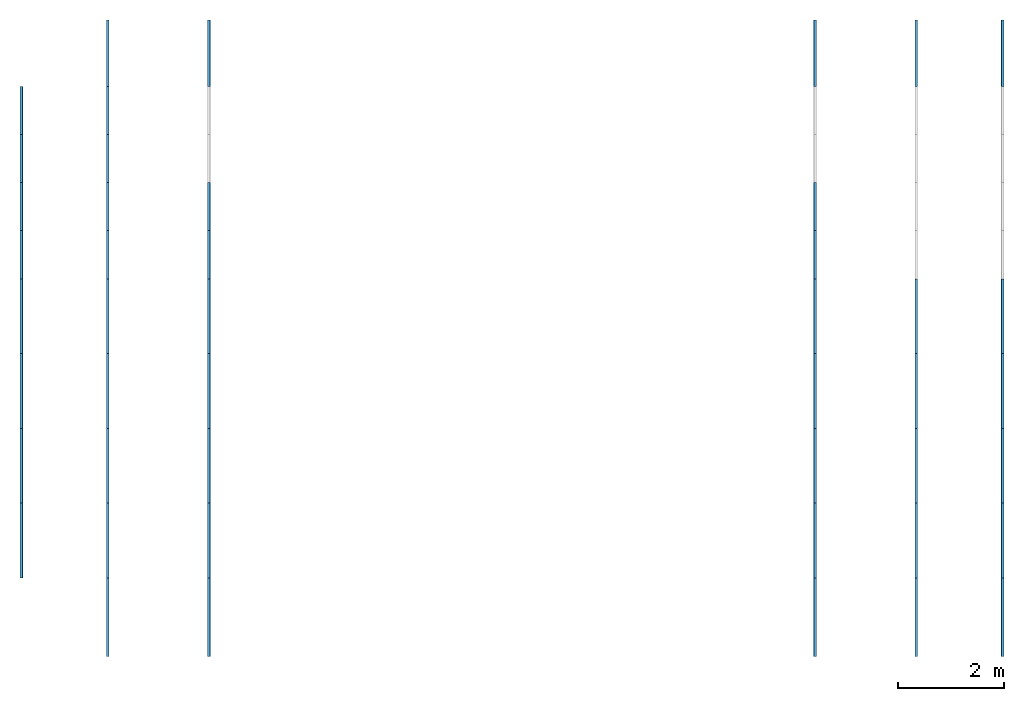
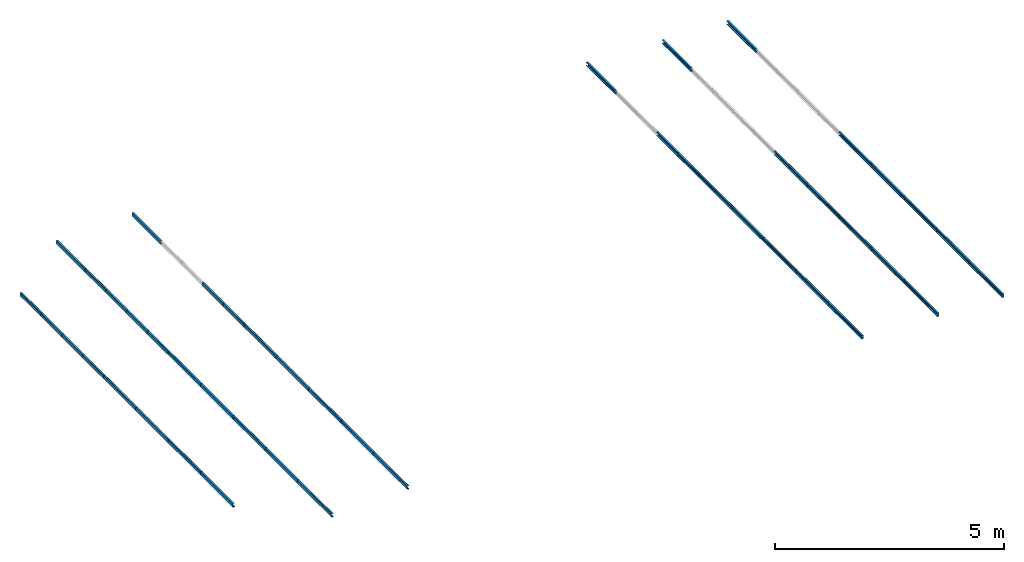
# One storey, part 1 of 2: 46 beams.
"""IFC4 building model written with IfcOpenShell, lengths in metres."""

from ifc_helpers import new_model, si_unit, derived_unit, frame, origin_with_axes, origin_2d_with_axis, place, context, project, spatial, c_section, extrude, material, material_profile, profile_set, profile_usage, element, save


model = new_model("IFC4")

# Units and contexts
model_context = context("Model", 3, world=origin_with_axes())
ifc_project = project(units=[si_unit("LENGTHUNIT", "METRE"), si_unit("AREAUNIT", "SQUARE_METRE"), si_unit("VOLUMEUNIT", "CUBIC_METRE"), derived_unit("SECTIONMODULUSUNIT", [(si_unit("LENGTHUNIT", "METRE"), 3)]), derived_unit("MOMENTOFINERTIAUNIT", [(si_unit("LENGTHUNIT", "METRE"), 4)]), si_unit("PLANEANGLEUNIT", "RADIAN"), si_unit("TIMEUNIT", "SECOND"), si_unit("THERMODYNAMICTEMPERATUREUNIT", "DEGREE_CELSIUS"), derived_unit("THERMALEXPANSIONCOEFFICIENTUNIT", [(si_unit("THERMODYNAMICTEMPERATUREUNIT", "DEGREE_CELSIUS"), -1)])], contexts=[model_context])

# Site, building, storey
site = spatial("IfcSite", under=ifc_project, CompositionType="ELEMENT")
building = spatial("IfcBuilding", under=site, Name="Building", CompositionType="ELEMENT")
storey = spatial("IfcBuildingStorey", under=building, Name="LEVEL 4", CompositionType="ELEMENT", Elevation=9.664)

# Beams
ifc_material = material(Name="SAE 1020")
ifc_material_profile_1 = material_profile(ifc_material, c_section(Depth=0.1, Width=0.05, WallThickness=0.003, Girth=0.017, InternalFilletRadius=0.003, at=origin_2d_with_axis()))
ifc_profile_set_1 = profile_set([ifc_material_profile_1])
ifc_profile_usage_1 = profile_usage(ifc_profile_set_1, cardinal=10)
beam_1_placement = place(None, frame((7.6291995, 8.75, 9.664), z_axis=(3.3783784e-07, 1.0, -3.0405405e-05), x_axis=(0.9992562, 8.3491316e-07, 0.038562213)))
element("IfcBeam", 1, at=beam_1_placement, inside=storey, material=ifc_profile_usage_1, Name="25", context=model_context, shape_type="SweptSolid", body=[
    extrude(c_section(Depth=0.1, Width=0.05, WallThickness=0.003, Girth=0.017, InternalFilletRadius=0.003, at=origin_2d_with_axis()), origin_with_axes(), (0.0, 0.0, 1.0), 1.48),
])
ifc_material_profile_2 = material_profile(ifc_material, c_section(Depth=0.1, Width=0.05, WallThickness=0.003, Girth=0.017, InternalFilletRadius=0.003, at=origin_2d_with_axis()))
ifc_profile_set_2 = profile_set([ifc_material_profile_2])
ifc_profile_usage_2 = profile_usage(ifc_profile_set_2, cardinal=10)
beam_2_placement = place(None, frame((7.6292, 19.5, 9.6639876), z_axis=(3.3783784e-07, 1.0, -3.0405405e-05), x_axis=(0.9992562, 8.3491316e-07, 0.038562213)))
element("IfcBeam", 2, at=beam_2_placement, inside=storey, material=ifc_profile_usage_2, Name="30", context=model_context, shape_type="SweptSolid", body=[
    extrude(c_section(Depth=0.1, Width=0.05, WallThickness=0.003, Girth=0.017, InternalFilletRadius=0.003, at=origin_2d_with_axis()), origin_with_axes(), (0.0, 0.0, 1.0), 1.25),
])
ifc_material_profile_3 = material_profile(ifc_material, c_section(Depth=0.1, Width=0.05, WallThickness=0.003, Girth=0.017, InternalFilletRadius=0.003, at=origin_2d_with_axis()))
ifc_profile_set_3 = profile_set([ifc_material_profile_3])
ifc_profile_usage_3 = profile_usage(ifc_profile_set_3, cardinal=10)
beam_3_placement = place(None, frame((9.5343995, 8.75, 9.7355), z_axis=(3.3783784e-07, 1.0, -3.0405405e-05), x_axis=(0.9992562, 8.3491316e-07, 0.038562213)))
element("IfcBeam", 3, at=beam_3_placement, inside=storey, material=ifc_profile_usage_3, Name="31", context=model_context, shape_type="SweptSolid", body=[
    extrude(c_section(Depth=0.1, Width=0.05, WallThickness=0.003, Girth=0.017, InternalFilletRadius=0.003, at=origin_2d_with_axis()), origin_with_axes(), (0.0, 0.0, 1.0), 1.48),
])
ifc_material_profile_4 = material_profile(ifc_material, c_section(Depth=0.1, Width=0.05, WallThickness=0.003, Girth=0.017, InternalFilletRadius=0.003, at=origin_2d_with_axis()))
ifc_profile_set_4 = profile_set([ifc_material_profile_4])
ifc_profile_usage_4 = profile_usage(ifc_profile_set_4, cardinal=10)
beam_4_placement = place(None, frame((9.5344, 19.5, 9.7354252), z_axis=(3.3783784e-07, 1.0, -3.0405405e-05), x_axis=(0.9992562, 8.3491316e-07, 0.038562213)))
element("IfcBeam", 4, at=beam_4_placement, inside=storey, material=ifc_profile_usage_4, Name="36", context=model_context, shape_type="SweptSolid", body=[
    extrude(c_section(Depth=0.1, Width=0.05, WallThickness=0.003, Girth=0.017, InternalFilletRadius=0.003, at=origin_2d_with_axis()), origin_with_axes(), (0.0, 0.0, 1.0), 1.25),
])
ifc_material_profile_5 = material_profile(ifc_material, c_section(Depth=0.1, Width=0.05, WallThickness=0.003, Girth=0.017, InternalFilletRadius=0.003, at=origin_2d_with_axis()))
ifc_profile_set_5 = profile_set([ifc_material_profile_5])
ifc_profile_usage_5 = profile_usage(ifc_profile_set_5, cardinal=10)
beam_5_placement = place(None, frame((24.5, 8.75, 9.6029), z_axis=(3.3783784e-07, 1.0, -3.0405405e-05), x_axis=(-0.9992562, 8.3491316e-07, 0.038562213)))
element("IfcBeam", 5, at=beam_5_placement, inside=storey, material=ifc_profile_usage_5, Name="150", context=model_context, shape_type="SweptSolid", body=[
    extrude(c_section(Depth=0.1, Width=0.05, WallThickness=0.003, Girth=0.017, InternalFilletRadius=0.003, at=origin_2d_with_axis()), origin_with_axes(), (0.0, 0.0, 1.0), 1.48),
])
ifc_material_profile_6 = material_profile(ifc_material, c_section(Depth=0.1, Width=0.05, WallThickness=0.003, Girth=0.017, InternalFilletRadius=0.003, at=origin_2d_with_axis()))
ifc_profile_set_6 = profile_set([ifc_material_profile_6])
ifc_profile_usage_6 = profile_usage(ifc_profile_set_6, cardinal=10)
beam_6_placement = place(None, frame((24.499999, 19.5, 9.602899), z_axis=(3.3783784e-07, 1.0, -3.0405405e-05), x_axis=(-0.9992562, 8.3491316e-07, 0.038562213)))
element("IfcBeam", 6, at=beam_6_placement, inside=storey, material=ifc_profile_usage_6, Name="155", context=model_context, shape_type="SweptSolid", body=[
    extrude(c_section(Depth=0.1, Width=0.05, WallThickness=0.003, Girth=0.017, InternalFilletRadius=0.003, at=origin_2d_with_axis()), origin_with_axes(), (0.0, 0.0, 1.0), 1.25),
])
ifc_material_profile_7 = material_profile(ifc_material, c_section(Depth=0.1, Width=0.05, WallThickness=0.003, Girth=0.017, InternalFilletRadius=0.003, at=origin_2d_with_axis()))
ifc_profile_set_7 = profile_set([ifc_material_profile_7])
ifc_profile_usage_7 = profile_usage(ifc_profile_set_7, cardinal=10)
beam_7_placement = place(None, frame((22.870801, 8.75, 9.664), z_axis=(3.3783784e-07, 1.0, -3.0405405e-05), x_axis=(-0.9992562, 8.3491316e-07, 0.038562213)))
element("IfcBeam", 7, at=beam_7_placement, inside=storey, material=ifc_profile_usage_7, Name="156", context=model_context, shape_type="SweptSolid", body=[
    extrude(c_section(Depth=0.1, Width=0.05, WallThickness=0.003, Girth=0.017, InternalFilletRadius=0.003, at=origin_2d_with_axis()), origin_with_axes(), (0.0, 0.0, 1.0), 1.48),
])
ifc_material_profile_8 = material_profile(ifc_material, c_section(Depth=0.1, Width=0.05, WallThickness=0.003, Girth=0.017, InternalFilletRadius=0.003, at=origin_2d_with_axis()))
ifc_profile_set_8 = profile_set([ifc_material_profile_8])
ifc_profile_usage_8 = profile_usage(ifc_profile_set_8, cardinal=10)
beam_8_placement = place(None, frame((22.8708, 19.5, 9.6639876), z_axis=(3.3783784e-07, 1.0, -3.0405405e-05), x_axis=(-0.9992562, 8.3491316e-07, 0.038562213)))
element("IfcBeam", 8, at=beam_8_placement, inside=storey, material=ifc_profile_usage_8, Name="161", context=model_context, shape_type="SweptSolid", body=[
    extrude(c_section(Depth=0.1, Width=0.05, WallThickness=0.003, Girth=0.017, InternalFilletRadius=0.003, at=origin_2d_with_axis()), origin_with_axes(), (0.0, 0.0, 1.0), 1.25),
])
ifc_material_profile_9 = material_profile(ifc_material, c_section(Depth=0.1, Width=0.05, WallThickness=0.003, Girth=0.017, InternalFilletRadius=0.003, at=origin_2d_with_axis()))
ifc_profile_set_9 = profile_set([ifc_material_profile_9])
ifc_profile_usage_9 = profile_usage(ifc_profile_set_9, cardinal=10)
beam_9_placement = place(None, frame((20.965601, 8.75, 9.7355), z_axis=(3.3783784e-07, 1.0, -3.0405405e-05), x_axis=(-0.9992562, 8.3491316e-07, 0.038562213)))
element("IfcBeam", 9, at=beam_9_placement, inside=storey, material=ifc_profile_usage_9, Name="162", context=model_context, shape_type="SweptSolid", body=[
    extrude(c_section(Depth=0.1, Width=0.05, WallThickness=0.003, Girth=0.017, InternalFilletRadius=0.003, at=origin_2d_with_axis()), origin_with_axes(), (0.0, 0.0, 1.0), 1.48),
])
ifc_material_profile_10 = material_profile(ifc_material, c_section(Depth=0.1, Width=0.05, WallThickness=0.003, Girth=0.017, InternalFilletRadius=0.003, at=origin_2d_with_axis()))
ifc_profile_set_10 = profile_set([ifc_material_profile_10])
ifc_profile_usage_10 = profile_usage(ifc_profile_set_10, cardinal=10)
beam_10_placement = place(None, frame((20.9656, 19.5, 9.7354252), z_axis=(3.3783784e-07, 1.0, -3.0405405e-05), x_axis=(-0.9992562, 8.3491316e-07, 0.038562213)))
element("IfcBeam", 10, at=beam_10_placement, inside=storey, material=ifc_profile_usage_10, Name="167", context=model_context, shape_type="SweptSolid", body=[
    extrude(c_section(Depth=0.1, Width=0.05, WallThickness=0.003, Girth=0.017, InternalFilletRadius=0.003, at=origin_2d_with_axis()), origin_with_axes(), (0.0, 0.0, 1.0), 1.25),
])
ifc_material_profile_11 = material_profile(ifc_material, c_section(Depth=0.1, Width=0.05, WallThickness=0.003, Girth=0.017, InternalFilletRadius=0.003, at=origin_2d_with_axis()))
ifc_profile_set_11 = profile_set([ifc_material_profile_11])
ifc_profile_usage_11 = profile_usage(ifc_profile_set_11, cardinal=10)
beam_11_placement = place(None, frame((6.0000007, 10.23, 9.602899), z_axis=(3.3783784e-07, 1.0, -3.0405405e-05), x_axis=(0.9992562, 8.3491316e-07, 0.038562213)))
element("IfcBeam", 11, at=beam_11_placement, inside=storey, material=ifc_profile_usage_11, Name="405", context=model_context, shape_type="SweptSolid", body=[
    extrude(c_section(Depth=0.1, Width=0.05, WallThickness=0.003, Girth=0.017, InternalFilletRadius=0.003, at=origin_2d_with_axis()), origin_with_axes(), (0.0, 0.0, 1.0), 1.41),
])
ifc_material_profile_12 = material_profile(ifc_material, c_section(Depth=0.1, Width=0.05, WallThickness=0.003, Girth=0.017, InternalFilletRadius=0.003, at=origin_2d_with_axis()))
ifc_profile_set_12 = profile_set([ifc_material_profile_12])
ifc_profile_usage_12 = profile_usage(ifc_profile_set_12, cardinal=10)
beam_12_placement = place(None, frame((6.0000007, 11.64, 9.602899), z_axis=(3.3783784e-07, 1.0, -3.0405405e-05), x_axis=(0.9992562, 8.3491316e-07, 0.038562213)))
element("IfcBeam", 12, at=beam_12_placement, inside=storey, material=ifc_profile_usage_12, Name="406", context=model_context, shape_type="SweptSolid", body=[
    extrude(c_section(Depth=0.1, Width=0.05, WallThickness=0.003, Girth=0.017, InternalFilletRadius=0.003, at=origin_2d_with_axis()), origin_with_axes(), (0.0, 0.0, 1.0), 1.41),
])
ifc_material_profile_13 = material_profile(ifc_material, c_section(Depth=0.1, Width=0.05, WallThickness=0.003, Girth=0.017, InternalFilletRadius=0.003, at=origin_2d_with_axis()))
ifc_profile_set_13 = profile_set([ifc_material_profile_13])
ifc_profile_usage_13 = profile_usage(ifc_profile_set_13, cardinal=10)
beam_13_placement = place(None, frame((6.0000007, 13.05, 9.602899), z_axis=(3.3783784e-07, 1.0, -3.0405405e-05), x_axis=(0.9992562, 8.3491316e-07, 0.038562213)))
element("IfcBeam", 13, at=beam_13_placement, inside=storey, material=ifc_profile_usage_13, Name="407", context=model_context, shape_type="SweptSolid", body=[
    extrude(c_section(Depth=0.1, Width=0.05, WallThickness=0.003, Girth=0.017, InternalFilletRadius=0.003, at=origin_2d_with_axis()), origin_with_axes(), (0.0, 0.0, 1.0), 1.41),
])
ifc_material_profile_14 = material_profile(ifc_material, c_section(Depth=0.1, Width=0.05, WallThickness=0.003, Girth=0.017, InternalFilletRadius=0.003, at=origin_2d_with_axis()))
ifc_profile_set_14 = profile_set([ifc_material_profile_14])
ifc_profile_usage_14 = profile_usage(ifc_profile_set_14, cardinal=10)
beam_14_placement = place(None, frame((6.0000007, 14.46, 9.602899), z_axis=(3.3783784e-07, 1.0, -3.0405405e-05), x_axis=(0.9992562, 8.3491316e-07, 0.038562213)))
element("IfcBeam", 14, at=beam_14_placement, inside=storey, material=ifc_profile_usage_14, Name="408", context=model_context, shape_type="SweptSolid", body=[
    extrude(c_section(Depth=0.1, Width=0.05, WallThickness=0.003, Girth=0.017, InternalFilletRadius=0.003, at=origin_2d_with_axis()), origin_with_axes(), (0.0, 0.0, 1.0), 1.41),
])
ifc_material_profile_15 = material_profile(ifc_material, c_section(Depth=0.1, Width=0.05, WallThickness=0.003, Girth=0.017, InternalFilletRadius=0.003, at=origin_2d_with_axis()))
ifc_profile_set_15 = profile_set([ifc_material_profile_15])
ifc_profile_usage_15 = profile_usage(ifc_profile_set_15, cardinal=10)
beam_15_placement = place(None, frame((6.0000007, 15.87, 9.602899), z_axis=(3.3783784e-07, 1.0, -3.0405405e-05), x_axis=(0.9992562, 8.3491316e-07, 0.038562213)))
element("IfcBeam", 15, at=beam_15_placement, inside=storey, material=ifc_profile_usage_15, Name="409", context=model_context, shape_type="SweptSolid", body=[
    extrude(c_section(Depth=0.1, Width=0.05, WallThickness=0.003, Girth=0.017, InternalFilletRadius=0.003, at=origin_2d_with_axis()), origin_with_axes(), (0.0, 0.0, 1.0), 0.9075),
])
ifc_material_profile_16 = material_profile(ifc_material, c_section(Depth=0.1, Width=0.05, WallThickness=0.003, Girth=0.017, InternalFilletRadius=0.003, at=origin_2d_with_axis()))
ifc_profile_set_16 = profile_set([ifc_material_profile_16])
ifc_profile_usage_16 = profile_usage(ifc_profile_set_16, cardinal=10)
beam_16_placement = place(None, frame((6.0000007, 16.7775, 9.602899), z_axis=(3.3783784e-07, 1.0, -3.0405405e-05), x_axis=(0.9992562, 8.3491316e-07, 0.038562213)))
element("IfcBeam", 16, at=beam_16_placement, inside=storey, material=ifc_profile_usage_16, Name="410", context=model_context, shape_type="SweptSolid", body=[
    extrude(c_section(Depth=0.1, Width=0.05, WallThickness=0.003, Girth=0.017, InternalFilletRadius=0.003, at=origin_2d_with_axis()), origin_with_axes(), (0.0, 0.0, 1.0), 0.9075),
])
ifc_material_profile_17 = material_profile(ifc_material, c_section(Depth=0.1, Width=0.05, WallThickness=0.003, Girth=0.017, InternalFilletRadius=0.003, at=origin_2d_with_axis()))
ifc_profile_set_17 = profile_set([ifc_material_profile_17])
ifc_profile_usage_17 = profile_usage(ifc_profile_set_17, cardinal=10)
beam_17_placement = place(None, frame((6.0000007, 17.685, 9.602899), z_axis=(3.3783784e-07, 1.0, -3.0405405e-05), x_axis=(0.9992562, 8.3491316e-07, 0.038562213)))
element("IfcBeam", 17, at=beam_17_placement, inside=storey, material=ifc_profile_usage_17, Name="411", context=model_context, shape_type="SweptSolid", body=[
    extrude(c_section(Depth=0.1, Width=0.05, WallThickness=0.003, Girth=0.017, InternalFilletRadius=0.003, at=origin_2d_with_axis()), origin_with_axes(), (0.0, 0.0, 1.0), 0.9075),
])
ifc_material_profile_18 = material_profile(ifc_material, c_section(Depth=0.1, Width=0.05, WallThickness=0.003, Girth=0.017, InternalFilletRadius=0.003, at=origin_2d_with_axis()))
ifc_profile_set_18 = profile_set([ifc_material_profile_18])
ifc_profile_usage_18 = profile_usage(ifc_profile_set_18, cardinal=10)
beam_18_placement = place(None, frame((6.0000007, 18.5925, 9.602899), z_axis=(3.3783784e-07, 1.0, -3.0405405e-05), x_axis=(0.9992562, 8.3491316e-07, 0.038562213)))
element("IfcBeam", 18, at=beam_18_placement, inside=storey, material=ifc_profile_usage_18, Name="412", context=model_context, shape_type="SweptSolid", body=[
    extrude(c_section(Depth=0.1, Width=0.05, WallThickness=0.003, Girth=0.017, InternalFilletRadius=0.003, at=origin_2d_with_axis()), origin_with_axes(), (0.0, 0.0, 1.0), 0.9075),
])
ifc_material_profile_19 = material_profile(ifc_material, c_section(Depth=0.1, Width=0.05, WallThickness=0.003, Girth=0.017, InternalFilletRadius=0.003, at=origin_2d_with_axis()))
ifc_profile_set_19 = profile_set([ifc_material_profile_19])
ifc_profile_usage_19 = profile_usage(ifc_profile_set_19, cardinal=10)
beam_19_placement = place(None, frame((7.6292, 10.23, 9.6639876), z_axis=(3.3783784e-07, 1.0, -3.0405405e-05), x_axis=(0.9992562, 8.3491316e-07, 0.038562213)))
element("IfcBeam", 19, at=beam_19_placement, inside=storey, material=ifc_profile_usage_19, Name="413", context=model_context, shape_type="SweptSolid", body=[
    extrude(c_section(Depth=0.1, Width=0.05, WallThickness=0.003, Girth=0.017, InternalFilletRadius=0.003, at=origin_2d_with_axis()), origin_with_axes(), (0.0, 0.0, 1.0), 1.41),
])
ifc_material_profile_20 = material_profile(ifc_material, c_section(Depth=0.1, Width=0.05, WallThickness=0.003, Girth=0.017, InternalFilletRadius=0.003, at=origin_2d_with_axis()))
ifc_profile_set_20 = profile_set([ifc_material_profile_20])
ifc_profile_usage_20 = profile_usage(ifc_profile_set_20, cardinal=10)
beam_20_placement = place(None, frame((7.6292, 11.64, 9.6639876), z_axis=(3.3783784e-07, 1.0, -3.0405405e-05), x_axis=(0.9992562, 8.3491316e-07, 0.038562213)))
element("IfcBeam", 20, at=beam_20_placement, inside=storey, material=ifc_profile_usage_20, Name="425", context=model_context, shape_type="SweptSolid", body=[
    extrude(c_section(Depth=0.1, Width=0.05, WallThickness=0.003, Girth=0.017, InternalFilletRadius=0.003, at=origin_2d_with_axis()), origin_with_axes(), (0.0, 0.0, 1.0), 1.41),
])
ifc_material_profile_21 = material_profile(ifc_material, c_section(Depth=0.1, Width=0.05, WallThickness=0.003, Girth=0.017, InternalFilletRadius=0.003, at=origin_2d_with_axis()))
ifc_profile_set_21 = profile_set([ifc_material_profile_21])
ifc_profile_usage_21 = profile_usage(ifc_profile_set_21, cardinal=10)
beam_21_placement = place(None, frame((7.6292, 13.05, 9.6639876), z_axis=(3.3783784e-07, 1.0, -3.0405405e-05), x_axis=(0.9992562, 8.3491316e-07, 0.038562213)))
element("IfcBeam", 21, at=beam_21_placement, inside=storey, material=ifc_profile_usage_21, Name="426", context=model_context, shape_type="SweptSolid", body=[
    extrude(c_section(Depth=0.1, Width=0.05, WallThickness=0.003, Girth=0.017, InternalFilletRadius=0.003, at=origin_2d_with_axis()), origin_with_axes(), (0.0, 0.0, 1.0), 1.41),
])
ifc_material_profile_22 = material_profile(ifc_material, c_section(Depth=0.1, Width=0.05, WallThickness=0.003, Girth=0.017, InternalFilletRadius=0.003, at=origin_2d_with_axis()))
ifc_profile_set_22 = profile_set([ifc_material_profile_22])
ifc_profile_usage_22 = profile_usage(ifc_profile_set_22, cardinal=10)
beam_22_placement = place(None, frame((7.6292, 14.46, 9.6639876), z_axis=(3.3783784e-07, 1.0, -3.0405405e-05), x_axis=(0.9992562, 8.3491316e-07, 0.038562213)))
element("IfcBeam", 22, at=beam_22_placement, inside=storey, material=ifc_profile_usage_22, Name="427", context=model_context, shape_type="SweptSolid", body=[
    extrude(c_section(Depth=0.1, Width=0.05, WallThickness=0.003, Girth=0.017, InternalFilletRadius=0.003, at=origin_2d_with_axis()), origin_with_axes(), (0.0, 0.0, 1.0), 1.41),
])
ifc_material_profile_23 = material_profile(ifc_material, c_section(Depth=0.1, Width=0.05, WallThickness=0.003, Girth=0.017, InternalFilletRadius=0.003, at=origin_2d_with_axis()))
ifc_profile_set_23 = profile_set([ifc_material_profile_23])
ifc_profile_usage_23 = profile_usage(ifc_profile_set_23, cardinal=10)
beam_23_placement = place(None, frame((7.6292, 15.87, 9.6639876), z_axis=(3.3783784e-07, 1.0, -3.0405405e-05), x_axis=(0.9992562, 8.3491316e-07, 0.038562213)))
element("IfcBeam", 23, at=beam_23_placement, inside=storey, material=ifc_profile_usage_23, Name="471", context=model_context, shape_type="SweptSolid", body=[
    extrude(c_section(Depth=0.1, Width=0.05, WallThickness=0.003, Girth=0.017, InternalFilletRadius=0.003, at=origin_2d_with_axis()), origin_with_axes(), (0.0, 0.0, 1.0), 0.9075),
])
ifc_material_profile_24 = material_profile(ifc_material, c_section(Depth=0.1, Width=0.05, WallThickness=0.003, Girth=0.017, InternalFilletRadius=0.003, at=origin_2d_with_axis()))
ifc_profile_set_24 = profile_set([ifc_material_profile_24])
ifc_profile_usage_24 = profile_usage(ifc_profile_set_24, cardinal=10)
beam_24_placement = place(None, frame((7.6292, 16.7775, 9.6639876), z_axis=(3.3783784e-07, 1.0, -3.0405405e-05), x_axis=(0.9992562, 8.3491316e-07, 0.038562213)))
element("IfcBeam", 24, at=beam_24_placement, inside=storey, material=ifc_profile_usage_24, Name="472", context=model_context, shape_type="SweptSolid", body=[
    extrude(c_section(Depth=0.1, Width=0.05, WallThickness=0.003, Girth=0.017, InternalFilletRadius=0.003, at=origin_2d_with_axis()), origin_with_axes(), (0.0, 0.0, 1.0), 0.9075),
])
ifc_material_profile_25 = material_profile(ifc_material, c_section(Depth=0.1, Width=0.05, WallThickness=0.003, Girth=0.017, InternalFilletRadius=0.003, at=origin_2d_with_axis()))
ifc_profile_set_25 = profile_set([ifc_material_profile_25])
ifc_profile_usage_25 = profile_usage(ifc_profile_set_25, cardinal=10)
beam_25_placement = place(None, frame((7.6292, 17.685, 9.6639876), z_axis=(3.3783784e-07, 1.0, -3.0405405e-05), x_axis=(0.9992562, 8.3491316e-07, 0.038562213)))
element("IfcBeam", 25, at=beam_25_placement, inside=storey, material=ifc_profile_usage_25, Name="473", context=model_context, shape_type="SweptSolid", body=[
    extrude(c_section(Depth=0.1, Width=0.05, WallThickness=0.003, Girth=0.017, InternalFilletRadius=0.003, at=origin_2d_with_axis()), origin_with_axes(), (0.0, 0.0, 1.0), 0.9075),
])
ifc_material_profile_26 = material_profile(ifc_material, c_section(Depth=0.1, Width=0.05, WallThickness=0.003, Girth=0.017, InternalFilletRadius=0.003, at=origin_2d_with_axis()))
ifc_profile_set_26 = profile_set([ifc_material_profile_26])
ifc_profile_usage_26 = profile_usage(ifc_profile_set_26, cardinal=10)
beam_26_placement = place(None, frame((7.6292, 18.5925, 9.6639876), z_axis=(3.3783784e-07, 1.0, -3.0405405e-05), x_axis=(0.9992562, 8.3491316e-07, 0.038562213)))
element("IfcBeam", 26, at=beam_26_placement, inside=storey, material=ifc_profile_usage_26, Name="475", context=model_context, shape_type="SweptSolid", body=[
    extrude(c_section(Depth=0.1, Width=0.05, WallThickness=0.003, Girth=0.017, InternalFilletRadius=0.003, at=origin_2d_with_axis()), origin_with_axes(), (0.0, 0.0, 1.0), 0.9075),
])
ifc_material_profile_27 = material_profile(ifc_material, c_section(Depth=0.1, Width=0.05, WallThickness=0.003, Girth=0.017, InternalFilletRadius=0.003, at=origin_2d_with_axis()))
ifc_profile_set_27 = profile_set([ifc_material_profile_27])
ifc_profile_usage_27 = profile_usage(ifc_profile_set_27, cardinal=10)
beam_27_placement = place(None, frame((9.5344, 10.23, 9.7354252), z_axis=(3.3783784e-07, 1.0, -3.0405405e-05), x_axis=(0.9992562, 8.3491316e-07, 0.038562213)))
element("IfcBeam", 27, at=beam_27_placement, inside=storey, material=ifc_profile_usage_27, Name="476", context=model_context, shape_type="SweptSolid", body=[
    extrude(c_section(Depth=0.1, Width=0.05, WallThickness=0.003, Girth=0.017, InternalFilletRadius=0.003, at=origin_2d_with_axis()), origin_with_axes(), (0.0, 0.0, 1.0), 1.41),
])
ifc_material_profile_28 = material_profile(ifc_material, c_section(Depth=0.1, Width=0.05, WallThickness=0.003, Girth=0.017, InternalFilletRadius=0.003, at=origin_2d_with_axis()))
ifc_profile_set_28 = profile_set([ifc_material_profile_28])
ifc_profile_usage_28 = profile_usage(ifc_profile_set_28, cardinal=10)
beam_28_placement = place(None, frame((9.5344, 11.64, 9.7354252), z_axis=(3.3783784e-07, 1.0, -3.0405405e-05), x_axis=(0.9992562, 8.3491316e-07, 0.038562213)))
element("IfcBeam", 28, at=beam_28_placement, inside=storey, material=ifc_profile_usage_28, Name="477", context=model_context, shape_type="SweptSolid", body=[
    extrude(c_section(Depth=0.1, Width=0.05, WallThickness=0.003, Girth=0.017, InternalFilletRadius=0.003, at=origin_2d_with_axis()), origin_with_axes(), (0.0, 0.0, 1.0), 1.41),
])
ifc_material_profile_29 = material_profile(ifc_material, c_section(Depth=0.1, Width=0.05, WallThickness=0.003, Girth=0.017, InternalFilletRadius=0.003, at=origin_2d_with_axis()))
ifc_profile_set_29 = profile_set([ifc_material_profile_29])
ifc_profile_usage_29 = profile_usage(ifc_profile_set_29, cardinal=10)
beam_29_placement = place(None, frame((9.5344, 13.05, 9.7354252), z_axis=(3.3783784e-07, 1.0, -3.0405405e-05), x_axis=(0.9992562, 8.3491316e-07, 0.038562213)))
element("IfcBeam", 29, at=beam_29_placement, inside=storey, material=ifc_profile_usage_29, Name="479", context=model_context, shape_type="SweptSolid", body=[
    extrude(c_section(Depth=0.1, Width=0.05, WallThickness=0.003, Girth=0.017, InternalFilletRadius=0.003, at=origin_2d_with_axis()), origin_with_axes(), (0.0, 0.0, 1.0), 1.41),
])
ifc_material_profile_30 = material_profile(ifc_material, c_section(Depth=0.1, Width=0.05, WallThickness=0.003, Girth=0.017, InternalFilletRadius=0.003, at=origin_2d_with_axis()))
ifc_profile_set_30 = profile_set([ifc_material_profile_30])
ifc_profile_usage_30 = profile_usage(ifc_profile_set_30, cardinal=10)
beam_30_placement = place(None, frame((9.5344, 14.46, 9.7354252), z_axis=(3.3783784e-07, 1.0, -3.0405405e-05), x_axis=(0.9992562, 8.3491316e-07, 0.038562213)))
element("IfcBeam", 30, at=beam_30_placement, inside=storey, material=ifc_profile_usage_30, Name="480", context=model_context, shape_type="SweptSolid", body=[
    extrude(c_section(Depth=0.1, Width=0.05, WallThickness=0.003, Girth=0.017, InternalFilletRadius=0.003, at=origin_2d_with_axis()), origin_with_axes(), (0.0, 0.0, 1.0), 1.41),
])
ifc_material_profile_31 = material_profile(ifc_material, c_section(Depth=0.1, Width=0.05, WallThickness=0.003, Girth=0.017, InternalFilletRadius=0.003, at=origin_2d_with_axis()))
ifc_profile_set_31 = profile_set([ifc_material_profile_31])
ifc_profile_usage_31 = profile_usage(ifc_profile_set_31, cardinal=10)
beam_31_placement = place(None, frame((9.5344, 15.87, 9.7354252), z_axis=(3.3783784e-07, 1.0, -3.0405405e-05), x_axis=(0.9992562, 8.3491316e-07, 0.038562213)))
element("IfcBeam", 31, at=beam_31_placement, inside=storey, material=ifc_profile_usage_31, Name="481", context=model_context, shape_type="SweptSolid", body=[
    extrude(c_section(Depth=0.1, Width=0.05, WallThickness=0.003, Girth=0.017, InternalFilletRadius=0.003, at=origin_2d_with_axis()), origin_with_axes(), (0.0, 0.0, 1.0), 0.9075),
])
ifc_material_profile_32 = material_profile(ifc_material, c_section(Depth=0.1, Width=0.05, WallThickness=0.003, Girth=0.017, InternalFilletRadius=0.003, at=origin_2d_with_axis()))
ifc_profile_set_32 = profile_set([ifc_material_profile_32])
ifc_profile_usage_32 = profile_usage(ifc_profile_set_32, cardinal=10)
beam_32_placement = place(None, frame((9.5344, 16.7775, 9.7354252), z_axis=(3.3783784e-07, 1.0, -3.0405405e-05), x_axis=(0.9992562, 8.3491316e-07, 0.038562213)))
element("IfcBeam", 32, at=beam_32_placement, inside=storey, material=ifc_profile_usage_32, Name="483", context=model_context, shape_type="SweptSolid", body=[
    extrude(c_section(Depth=0.1, Width=0.05, WallThickness=0.003, Girth=0.017, InternalFilletRadius=0.003, at=origin_2d_with_axis()), origin_with_axes(), (0.0, 0.0, 1.0), 0.9075),
])
ifc_material_profile_33 = material_profile(ifc_material, c_section(Depth=0.1, Width=0.05, WallThickness=0.003, Girth=0.017, InternalFilletRadius=0.003, at=origin_2d_with_axis()))
ifc_profile_set_33 = profile_set([ifc_material_profile_33])
ifc_profile_usage_33 = profile_usage(ifc_profile_set_33, cardinal=10)
beam_33_placement = place(None, frame((24.499999, 10.23, 9.602899), z_axis=(3.3783784e-07, 1.0, -3.0405405e-05), x_axis=(-0.9992562, 8.3491316e-07, 0.038562213)))
element("IfcBeam", 33, at=beam_33_placement, inside=storey, material=ifc_profile_usage_33, Name="952", context=model_context, shape_type="SweptSolid", body=[
    extrude(c_section(Depth=0.1, Width=0.05, WallThickness=0.003, Girth=0.017, InternalFilletRadius=0.003, at=origin_2d_with_axis()), origin_with_axes(), (0.0, 0.0, 1.0), 1.41),
])
ifc_material_profile_34 = material_profile(ifc_material, c_section(Depth=0.1, Width=0.05, WallThickness=0.003, Girth=0.017, InternalFilletRadius=0.003, at=origin_2d_with_axis()))
ifc_profile_set_34 = profile_set([ifc_material_profile_34])
ifc_profile_usage_34 = profile_usage(ifc_profile_set_34, cardinal=10)
beam_34_placement = place(None, frame((24.499999, 11.64, 9.602899), z_axis=(3.3783784e-07, 1.0, -3.0405405e-05), x_axis=(-0.9992562, 8.3491316e-07, 0.038562213)))
element("IfcBeam", 34, at=beam_34_placement, inside=storey, material=ifc_profile_usage_34, Name="953", context=model_context, shape_type="SweptSolid", body=[
    extrude(c_section(Depth=0.1, Width=0.05, WallThickness=0.003, Girth=0.017, InternalFilletRadius=0.003, at=origin_2d_with_axis()), origin_with_axes(), (0.0, 0.0, 1.0), 1.41),
])
ifc_material_profile_35 = material_profile(ifc_material, c_section(Depth=0.1, Width=0.05, WallThickness=0.003, Girth=0.017, InternalFilletRadius=0.003, at=origin_2d_with_axis()))
ifc_profile_set_35 = profile_set([ifc_material_profile_35])
ifc_profile_usage_35 = profile_usage(ifc_profile_set_35, cardinal=10)
beam_35_placement = place(None, frame((24.499999, 13.05, 9.602899), z_axis=(3.3783784e-07, 1.0, -3.0405405e-05), x_axis=(-0.9992562, 8.3491316e-07, 0.038562213)))
element("IfcBeam", 35, at=beam_35_placement, inside=storey, material=ifc_profile_usage_35, Name="956", context=model_context, shape_type="SweptSolid", body=[
    extrude(c_section(Depth=0.1, Width=0.05, WallThickness=0.003, Girth=0.017, InternalFilletRadius=0.003, at=origin_2d_with_axis()), origin_with_axes(), (0.0, 0.0, 1.0), 1.41),
])
ifc_material_profile_36 = material_profile(ifc_material, c_section(Depth=0.1, Width=0.05, WallThickness=0.003, Girth=0.017, InternalFilletRadius=0.003, at=origin_2d_with_axis()))
ifc_profile_set_36 = profile_set([ifc_material_profile_36])
ifc_profile_usage_36 = profile_usage(ifc_profile_set_36, cardinal=10)
beam_36_placement = place(None, frame((24.499999, 14.46, 9.602899), z_axis=(3.3783784e-07, 1.0, -3.0405405e-05), x_axis=(-0.9992562, 8.3491316e-07, 0.038562213)))
element("IfcBeam", 36, at=beam_36_placement, inside=storey, material=ifc_profile_usage_36, Name="957", context=model_context, shape_type="SweptSolid", body=[
    extrude(c_section(Depth=0.1, Width=0.05, WallThickness=0.003, Girth=0.017, InternalFilletRadius=0.003, at=origin_2d_with_axis()), origin_with_axes(), (0.0, 0.0, 1.0), 1.41),
])
ifc_material_profile_37 = material_profile(ifc_material, c_section(Depth=0.1, Width=0.05, WallThickness=0.003, Girth=0.017, InternalFilletRadius=0.003, at=origin_2d_with_axis()))
ifc_profile_set_37 = profile_set([ifc_material_profile_37])
ifc_profile_usage_37 = profile_usage(ifc_profile_set_37, cardinal=10)
beam_37_placement = place(None, frame((22.8708, 10.23, 9.6639876), z_axis=(3.3783784e-07, 1.0, -3.0405405e-05), x_axis=(-0.9992562, 8.3491316e-07, 0.038562213)))
element("IfcBeam", 37, at=beam_37_placement, inside=storey, material=ifc_profile_usage_37, Name="968", context=model_context, shape_type="SweptSolid", body=[
    extrude(c_section(Depth=0.1, Width=0.05, WallThickness=0.003, Girth=0.017, InternalFilletRadius=0.003, at=origin_2d_with_axis()), origin_with_axes(), (0.0, 0.0, 1.0), 1.41),
])
ifc_material_profile_38 = material_profile(ifc_material, c_section(Depth=0.1, Width=0.05, WallThickness=0.003, Girth=0.017, InternalFilletRadius=0.003, at=origin_2d_with_axis()))
ifc_profile_set_38 = profile_set([ifc_material_profile_38])
ifc_profile_usage_38 = profile_usage(ifc_profile_set_38, cardinal=10)
beam_38_placement = place(None, frame((22.8708, 11.64, 9.6639876), z_axis=(3.3783784e-07, 1.0, -3.0405405e-05), x_axis=(-0.9992562, 8.3491316e-07, 0.038562213)))
element("IfcBeam", 38, at=beam_38_placement, inside=storey, material=ifc_profile_usage_38, Name="969", context=model_context, shape_type="SweptSolid", body=[
    extrude(c_section(Depth=0.1, Width=0.05, WallThickness=0.003, Girth=0.017, InternalFilletRadius=0.003, at=origin_2d_with_axis()), origin_with_axes(), (0.0, 0.0, 1.0), 1.41),
])
ifc_material_profile_39 = material_profile(ifc_material, c_section(Depth=0.1, Width=0.05, WallThickness=0.003, Girth=0.017, InternalFilletRadius=0.003, at=origin_2d_with_axis()))
ifc_profile_set_39 = profile_set([ifc_material_profile_39])
ifc_profile_usage_39 = profile_usage(ifc_profile_set_39, cardinal=10)
beam_39_placement = place(None, frame((22.8708, 13.05, 9.6639876), z_axis=(3.3783784e-07, 1.0, -3.0405405e-05), x_axis=(-0.9992562, 8.3491316e-07, 0.038562213)))
element("IfcBeam", 39, at=beam_39_placement, inside=storey, material=ifc_profile_usage_39, Name="970", context=model_context, shape_type="SweptSolid", body=[
    extrude(c_section(Depth=0.1, Width=0.05, WallThickness=0.003, Girth=0.017, InternalFilletRadius=0.003, at=origin_2d_with_axis()), origin_with_axes(), (0.0, 0.0, 1.0), 1.41),
])
ifc_material_profile_40 = material_profile(ifc_material, c_section(Depth=0.1, Width=0.05, WallThickness=0.003, Girth=0.017, InternalFilletRadius=0.003, at=origin_2d_with_axis()))
ifc_profile_set_40 = profile_set([ifc_material_profile_40])
ifc_profile_usage_40 = profile_usage(ifc_profile_set_40, cardinal=10)
beam_40_placement = place(None, frame((22.8708, 14.46, 9.6639876), z_axis=(3.3783784e-07, 1.0, -3.0405405e-05), x_axis=(-0.9992562, 8.3491316e-07, 0.038562213)))
element("IfcBeam", 40, at=beam_40_placement, inside=storey, material=ifc_profile_usage_40, Name="971", context=model_context, shape_type="SweptSolid", body=[
    extrude(c_section(Depth=0.1, Width=0.05, WallThickness=0.003, Girth=0.017, InternalFilletRadius=0.003, at=origin_2d_with_axis()), origin_with_axes(), (0.0, 0.0, 1.0), 1.41),
])
ifc_material_profile_41 = material_profile(ifc_material, c_section(Depth=0.1, Width=0.05, WallThickness=0.003, Girth=0.017, InternalFilletRadius=0.003, at=origin_2d_with_axis()))
ifc_profile_set_41 = profile_set([ifc_material_profile_41])
ifc_profile_usage_41 = profile_usage(ifc_profile_set_41, cardinal=10)
beam_41_placement = place(None, frame((20.9656, 10.23, 9.7354252), z_axis=(3.3783784e-07, 1.0, -3.0405405e-05), x_axis=(-0.9992562, 8.3491316e-07, 0.038562213)))
element("IfcBeam", 41, at=beam_41_placement, inside=storey, material=ifc_profile_usage_41, Name="976", context=model_context, shape_type="SweptSolid", body=[
    extrude(c_section(Depth=0.1, Width=0.05, WallThickness=0.003, Girth=0.017, InternalFilletRadius=0.003, at=origin_2d_with_axis()), origin_with_axes(), (0.0, 0.0, 1.0), 1.41),
])
ifc_material_profile_42 = material_profile(ifc_material, c_section(Depth=0.1, Width=0.05, WallThickness=0.003, Girth=0.017, InternalFilletRadius=0.003, at=origin_2d_with_axis()))
ifc_profile_set_42 = profile_set([ifc_material_profile_42])
ifc_profile_usage_42 = profile_usage(ifc_profile_set_42, cardinal=10)
beam_42_placement = place(None, frame((20.9656, 11.64, 9.7354252), z_axis=(3.3783784e-07, 1.0, -3.0405405e-05), x_axis=(-0.9992562, 8.3491316e-07, 0.038562213)))
element("IfcBeam", 42, at=beam_42_placement, inside=storey, material=ifc_profile_usage_42, Name="977", context=model_context, shape_type="SweptSolid", body=[
    extrude(c_section(Depth=0.1, Width=0.05, WallThickness=0.003, Girth=0.017, InternalFilletRadius=0.003, at=origin_2d_with_axis()), origin_with_axes(), (0.0, 0.0, 1.0), 1.41),
])
ifc_material_profile_43 = material_profile(ifc_material, c_section(Depth=0.1, Width=0.05, WallThickness=0.003, Girth=0.017, InternalFilletRadius=0.003, at=origin_2d_with_axis()))
ifc_profile_set_43 = profile_set([ifc_material_profile_43])
ifc_profile_usage_43 = profile_usage(ifc_profile_set_43, cardinal=10)
beam_43_placement = place(None, frame((20.9656, 13.05, 9.7354252), z_axis=(3.3783784e-07, 1.0, -3.0405405e-05), x_axis=(-0.9992562, 8.3491316e-07, 0.038562213)))
element("IfcBeam", 43, at=beam_43_placement, inside=storey, material=ifc_profile_usage_43, Name="989", context=model_context, shape_type="SweptSolid", body=[
    extrude(c_section(Depth=0.1, Width=0.05, WallThickness=0.003, Girth=0.017, InternalFilletRadius=0.003, at=origin_2d_with_axis()), origin_with_axes(), (0.0, 0.0, 1.0), 1.41),
])
ifc_material_profile_44 = material_profile(ifc_material, c_section(Depth=0.1, Width=0.05, WallThickness=0.003, Girth=0.017, InternalFilletRadius=0.003, at=origin_2d_with_axis()))
ifc_profile_set_44 = profile_set([ifc_material_profile_44])
ifc_profile_usage_44 = profile_usage(ifc_profile_set_44, cardinal=10)
beam_44_placement = place(None, frame((20.9656, 14.46, 9.7354252), z_axis=(3.3783784e-07, 1.0, -3.0405405e-05), x_axis=(-0.9992562, 8.3491316e-07, 0.038562213)))
element("IfcBeam", 44, at=beam_44_placement, inside=storey, material=ifc_profile_usage_44, Name="990", context=model_context, shape_type="SweptSolid", body=[
    extrude(c_section(Depth=0.1, Width=0.05, WallThickness=0.003, Girth=0.017, InternalFilletRadius=0.003, at=origin_2d_with_axis()), origin_with_axes(), (0.0, 0.0, 1.0), 1.41),
])
ifc_material_profile_45 = material_profile(ifc_material, c_section(Depth=0.1, Width=0.05, WallThickness=0.003, Girth=0.017, InternalFilletRadius=0.003, at=origin_2d_with_axis()))
ifc_profile_set_45 = profile_set([ifc_material_profile_45])
ifc_profile_usage_45 = profile_usage(ifc_profile_set_45, cardinal=10)
beam_45_placement = place(None, frame((20.9656, 15.87, 9.7354252), z_axis=(3.3783784e-07, 1.0, -3.0405405e-05), x_axis=(-0.9992562, 8.3491316e-07, 0.038562213)))
element("IfcBeam", 45, at=beam_45_placement, inside=storey, material=ifc_profile_usage_45, Name="991", context=model_context, shape_type="SweptSolid", body=[
    extrude(c_section(Depth=0.1, Width=0.05, WallThickness=0.003, Girth=0.017, InternalFilletRadius=0.003, at=origin_2d_with_axis()), origin_with_axes(), (0.0, 0.0, 1.0), 0.9075),
])
ifc_material_profile_46 = material_profile(ifc_material, c_section(Depth=0.1, Width=0.05, WallThickness=0.003, Girth=0.017, InternalFilletRadius=0.003, at=origin_2d_with_axis()))
ifc_profile_set_46 = profile_set([ifc_material_profile_46])
ifc_profile_usage_46 = profile_usage(ifc_profile_set_46, cardinal=10)
beam_46_placement = place(None, frame((20.9656, 16.7775, 9.7354252), z_axis=(3.3783784e-07, 1.0, -3.0405405e-05), x_axis=(-0.9992562, 8.3491316e-07, 0.038562213)))
element("IfcBeam", 46, at=beam_46_placement, inside=storey, material=ifc_profile_usage_46, Name="992", context=model_context, shape_type="SweptSolid", body=[
    extrude(c_section(Depth=0.1, Width=0.05, WallThickness=0.003, Girth=0.017, InternalFilletRadius=0.003, at=origin_2d_with_axis()), origin_with_axes(), (0.0, 0.0, 1.0), 0.9075),
])

save(model, "model.ifc")
